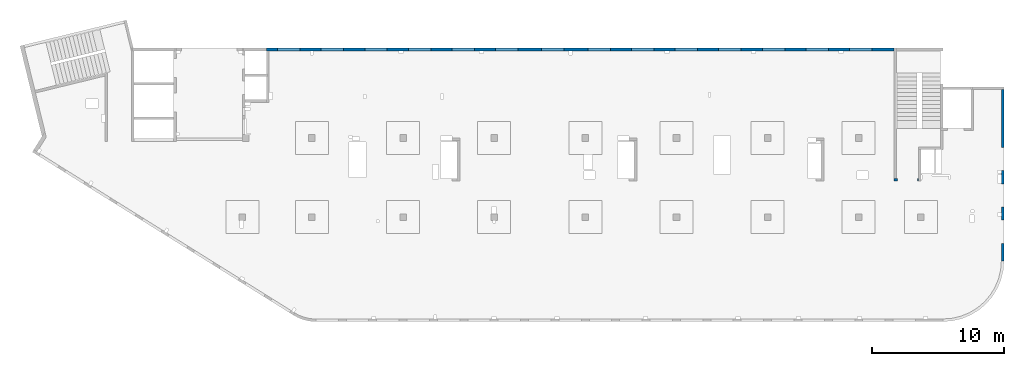
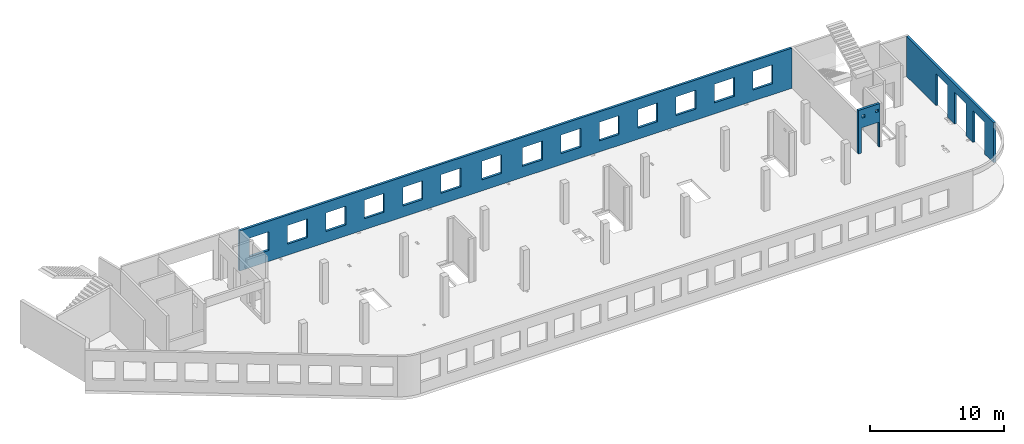
# One storey, part 6 of 6: 3 walls, 20 openings.
"""IFC4 building model written with IfcOpenShell, lengths in millimetres."""

from ifc_helpers import new_model, entity, si_unit, converted_unit, derived_unit, direction, frame, origin, place, context, subcontext, project, spatial, indexed_curve, outline, extrude, polygons, material, type_object, element, save


model = new_model("IFC4")

# Units and contexts
model_context = context("Model", 3, precision=0.01, world=origin(), true_north=direction((6.12303176911189e-17, 1.0)))
plan_context = context("Plan", 3, precision=0.01, world=origin(), true_north=direction((6.12303176911189e-17, 1.0)))
body_context = subcontext(model_context, "Body", "Model", "MODEL_VIEW")
ifc_project = project(units=[si_unit("LENGTHUNIT", "METRE", prefix="MILLI"), si_unit("AREAUNIT", "SQUARE_METRE"), si_unit("VOLUMEUNIT", "CUBIC_METRE"), converted_unit("PLANEANGLEUNIT", "DEGREE", entity("IfcRatioMeasure", 0.0174532925199433), si_unit("PLANEANGLEUNIT", "RADIAN"), dimensions=[0, 0, 0, 0, 0, 0, 0]), si_unit("MASSUNIT", "GRAM", prefix="KILO"), derived_unit("MASSDENSITYUNIT", [(si_unit("MASSUNIT", "GRAM", prefix="KILO"), 1), (si_unit("LENGTHUNIT", "METRE"), -3)]), derived_unit("MOMENTOFINERTIAUNIT", [(si_unit("LENGTHUNIT", "METRE"), 4)]), si_unit("TIMEUNIT", "SECOND"), si_unit("FREQUENCYUNIT", "HERTZ"), si_unit("THERMODYNAMICTEMPERATUREUNIT", "DEGREE_CELSIUS"), derived_unit("THERMALTRANSMITTANCEUNIT", [(si_unit("MASSUNIT", "GRAM", prefix="KILO"), 1), (si_unit("THERMODYNAMICTEMPERATUREUNIT", "KELVIN"), -1), (si_unit("TIMEUNIT", "SECOND"), -3)]), derived_unit("VOLUMETRICFLOWRATEUNIT", [(si_unit("LENGTHUNIT", "METRE"), 3), (si_unit("TIMEUNIT", "SECOND"), -1)]), derived_unit("MASSFLOWRATEUNIT", [(si_unit("MASSUNIT", "GRAM", prefix="KILO"), 1), (si_unit("TIMEUNIT", "SECOND"), -1)]), derived_unit("ROTATIONALFREQUENCYUNIT", [(si_unit("TIMEUNIT", "SECOND"), -1)]), si_unit("ELECTRICCURRENTUNIT", "AMPERE"), si_unit("ELECTRICVOLTAGEUNIT", "VOLT"), si_unit("POWERUNIT", "WATT"), si_unit("FORCEUNIT", "NEWTON", prefix="KILO"), si_unit("ILLUMINANCEUNIT", "LUX"), si_unit("LUMINOUSFLUXUNIT", "LUMEN"), si_unit("LUMINOUSINTENSITYUNIT", "CANDELA"), derived_unit("USERDEFINED", [(si_unit("MASSUNIT", "GRAM", prefix="KILO"), -1), (si_unit("LENGTHUNIT", "METRE"), -2), (si_unit("TIMEUNIT", "SECOND"), 3), (si_unit("LUMINOUSFLUXUNIT", "LUMEN"), 1)]), derived_unit("LINEARVELOCITYUNIT", [(si_unit("LENGTHUNIT", "METRE"), 1), (si_unit("TIMEUNIT", "SECOND"), -1)]), si_unit("PRESSUREUNIT", "PASCAL"), derived_unit("USERDEFINED", [(si_unit("LENGTHUNIT", "METRE"), -2), (si_unit("MASSUNIT", "GRAM", prefix="KILO"), 1), (si_unit("TIMEUNIT", "SECOND"), -2)]), derived_unit("LINEARFORCEUNIT", [(si_unit("MASSUNIT", "GRAM", prefix="KILO"), 1), (si_unit("LENGTHUNIT", "METRE"), 1), (si_unit("TIMEUNIT", "SECOND"), -2), (si_unit("LENGTHUNIT", "METRE"), -1)]), derived_unit("PLANARFORCEUNIT", [(si_unit("MASSUNIT", "GRAM", prefix="KILO"), 1), (si_unit("LENGTHUNIT", "METRE"), 1), (si_unit("TIMEUNIT", "SECOND"), -2), (si_unit("LENGTHUNIT", "METRE"), -2)])], contexts=[model_context, plan_context])

# Site, building, storey
site_placement = place(None, origin())
site = spatial("IfcSite", under=ifc_project, at=site_placement, CompositionType="ELEMENT")
building_placement = place(site_placement, origin())
building = spatial("IfcBuilding", under=site, at=building_placement, CompositionType="ELEMENT")
storey_placement = place(building_placement, frame((0.0, 0.0, 12000.0)))
storey = spatial("IfcBuildingStorey", under=building, at=storey_placement, Name="04", CompositionType="ELEMENT", Elevation=12000.0)

# Wall, openings
ifc_material = material()
wall_type = type_object("IfcWallType", Name=":ADSK_ 25_200", PredefinedType="STANDARD")
wall_1_placement = place(storey_placement, frame((73470.0, 17370.0, -150.0), z_axis=(0.0, 0.0, 1.0), x_axis=(0.0, -1.0, 0.0)))
wall_1 = element("IfcWall", 1, at=wall_1_placement, inside=storey, type_object=wall_type, material=ifc_material, Name=":ADSK_ 25_200", ObjectType=":ADSK_ 25_200", PredefinedType="NOTDEFINED", context=body_context, shape_type="Tessellation", body=[
    polygons([(12970.0, -99.9999999999918, 0.0), (12970.0, -99.9999999999918, 3200.0), (12970.0, -99.9999999999918, 3650.0), (9560.00000000002, -99.9999999999877, 3650.0), (9360.00000000002, -99.999999999988, 3650.0), (7085.00000000004, -99.999999999991, 3650.0), (6485.00000000003, -99.9999999999918, 3650.0), (6320.00000000002, -99.999999999992, 3650.0), (6120.00000000002, -99.9999999999923, 3650.0), (0.0, -99.9999999999831, 3650.0), (0.0, -99.9999999999831, 0.0), (4394.99999999951, -99.9999999999946, 0.0), (4394.99999999951, -100.000000000003, 2900.0), (6144.99999999951, -100.000000000001, 2900.0), (6144.99999999951, -99.9999999999923, 0.0), (6320.00000000002, -99.999999999992, 0.0), (6485.00000000003, -99.9999999999918, 0.0), (7085.00000000004, -99.999999999991, 0.0), (7144.99999999951, -99.9999999999909, 0.0), (7144.99999999951, -99.9999999999996, 2900.0), (8894.99999999951, -99.9999999999972, 2900.0), (8894.99999999951, -99.9999999999886, 0.0), (9360.00000000002, -99.999999999988, 0.0), (9560.00000000003, -99.9999999999877, 0.0), (9894.99999999951, -99.9999999999959, 0.0), (9894.99999999951, -99.9999999999959, 2900.0), (11644.9999999995, -99.9999999999936, 2900.0), (11644.9999999995, -99.9999999999936, 0.0), (12970.0, 100.000000000006, 3650.0), (12970.0, 100.000000000006, 3200.0), (12970.0, 100.000000000006, 0.0), (11644.9999999995, 100.000000000004, 0.0), (11644.9999999995, 100.000000000316, 2900.0), (9894.99999999951, 100.000000000314, 2900.0), (9894.99999999951, 100.000000000002, 0.0), (8894.99999999951, 100.000000000001, 0.0), (8894.99999999951, 100.00000000033, 2900.0), (7144.99999999951, 100.000000000327, 2900.0), (7144.99999999951, 99.9999999999983, 0.0), (6144.99999999951, 99.9999999999969, 0.0), (6144.99999999951, 100.000000000326, 2900.0), (4394.99999999951, 100.000000000324, 2900.0), (4394.99999999951, 99.9999999999946, 0.0), (0.0, 100.000000000006, 0.0), (0.0, 100.000000000006, 3650.0)], [[[1, 2, 3, 4, 5, 6, 7, 8, 9, 10, 11, 12, 13, 14, 15, 16, 17, 18, 19, 20, 21, 22, 23, 24, 25, 26, 27, 28]], [[29, 30, 31, 32, 33, 34, 35, 36, 37, 38, 39, 40, 41, 42, 43, 44, 45]], [[11, 44, 43, 12]], [[3, 2, 1, 31, 30, 29]], [[10, 9, 8, 7, 6, 5, 4, 3, 29, 45]], [[11, 10, 45, 44]], [[26, 34, 33, 27]], [[34, 26, 25, 35]], [[27, 33, 32, 28]], [[20, 38, 37, 21]], [[38, 20, 19, 39]], [[21, 37, 36, 22]], [[13, 42, 41, 14]], [[42, 13, 12, 43]], [[14, 41, 40, 15]], [[39, 19, 18, 17, 16, 15, 40]], [[35, 25, 24, 23, 22, 36]], [[31, 1, 28, 32]]], closed=True),
])
placement_1 = place(wall_1_placement, frame((17370.0, -73470.0, 150.0), z_axis=(0.0, 0.0, 1.0), x_axis=(0.0, 1.0, 0.0)))
element("IfcOpeningElement", 2, at=placement_1, cuts=wall_1, Name=":ADSK_ 25_200", PredefinedType="OPENING", context=body_context, shape_type="SweptSolid", body=[
    extrude(outline(indexed_curve([(-1449.99999999999, -874.999999999999), (1449.99999999999, -874.999999999999), (1449.99999999999, 875.0), (-1449.99999999999, 875.0), (-1449.99999999999, -874.999999999999)], self_intersect=False)), frame((73370.0, 6600.0, 1300.0), z_axis=(1.0, 0.0, 0.0), x_axis=(0.0, 0.0, -1.0)), (0.0, 0.0, 1.0), 200.000000000968),
])
element("IfcOpeningElement", 3, at=placement_1, cuts=wall_1, Name=":ADSK_ 25_200", PredefinedType="OPENING", context=body_context, shape_type="SweptSolid", body=[
    extrude(outline(indexed_curve([(-1449.99999999999, -875.0), (1449.99999999999, -875.0), (1449.99999999999, 874.999999999999), (-1449.99999999999, 874.999999999999), (-1449.99999999999, -875.0)], self_intersect=False)), frame((73370.0, 9350.0, 1300.0), z_axis=(1.0, 0.0, 0.0), x_axis=(0.0, 0.0, -1.0)), (0.0, 0.0, 1.0), 200.000000000968),
])
element("IfcOpeningElement", 4, at=placement_1, cuts=wall_1, Name=":ADSK_ 25_200", PredefinedType="OPENING", context=body_context, shape_type="SweptSolid", body=[
    extrude(outline(indexed_curve([(-1449.99999999999, -875.0), (1449.99999999999, -875.0), (1449.99999999999, 875.0), (-1449.99999999999, 875.0), (-1449.99999999999, -875.0)], self_intersect=False)), frame((73370.0, 12100.0, 1300.0), z_axis=(1.0, 0.0, 0.0), x_axis=(0.0, 0.0, -1.0)), (0.0, 0.0, 1.0), 200.000000000968),
])

wall_2_placement = place(storey_placement, frame((67080.0, 10525.0, -150.0), z_axis=(0.0, 0.0, 1.0), x_axis=(-1.0, 0.0, 0.0)))
wall_2 = element("IfcWall", 5, at=wall_2_placement, inside=storey, type_object=wall_type, material=ifc_material, Name=":ADSK_ 25_200", ObjectType=":ADSK_ 25_200", PredefinedType="NOTDEFINED", context=body_context, shape_type="Tessellation", body=[
    polygons([(1849.99999999999, -100.000000000001, 3950.0), (-9.772240076716e-13, -100.000000000001, 3950.0), (-9.772240076716e-13, -100.000000000001, 0.0), (74.9999999999906, -100.000000000001, 0.0), (74.9999999999906, -100.000000000001, 2279.99999999805), (1575.0, -100.000000000001, 2279.99999999804), (1575.0, -100.000000000003, 0.0), (1650.0, -100.000000000003, 0.0), (1849.99999999999, -100.000000000001, 0.0), (1849.99999999999, -100.000000000001, 3650.0), (125.000000000014, -100.000000000322, 3490.0), (375.000000000009, -100.000000000324, 3490.0), (375.000000000009, -100.000000000324, 3240.00000000001), (125.000000000014, -100.000000000322, 3240.00000000001), (1275.0, -100.000000000322, 3400.0), (1524.99999999999, -100.000000000322, 3400.0), (1524.99999999999, -100.000000000322, 3150.00000000001), (1275.0, -100.000000000322, 3150.00000000001), (-1.61109744921212e-12, 99.9999999999989, 3950.0), (1849.99999999999, 99.9999999999989, 3950.0), (1849.99999999999, 99.9999999999989, 0.0), (1575.0, 99.9999999999968, 0.0), (1575.0, 99.9999999999968, 2279.99999999804), (74.99999999999, 99.9999999999989, 2279.99999999805), (74.99999999999, 99.9999999999989, 0.0), (-1.61109744921212e-12, 99.9999999999989, 0.0), (375.000000000008, 99.9999999999968, 3490.0), (125.000000000013, 99.9999999999968, 3490.0), (125.000000000013, 99.9999999999968, 3240.00000000001), (375.000000000008, 99.9999999999968, 3240.00000000001), (1524.99999999999, 99.9999999999968, 3400.0), (1275.0, 99.9999999999989, 3400.0), (1275.0, 99.9999999999989, 3150.00000000001), (1524.99999999999, 99.9999999999968, 3150.00000000001)], [[[1, 2, 3, 4, 5, 6, 7, 8, 9, 10], [11, 12, 13, 14], [15, 16, 17, 18]], [[19, 20, 21, 22, 23, 24, 25, 26], [27, 28, 29, 30], [31, 32, 33, 34]], [[3, 26, 25, 4]], [[2, 1, 20, 19]], [[3, 2, 19, 26]], [[1, 10, 9, 21, 20]], [[12, 11, 28, 27]], [[12, 27, 30, 13]], [[13, 30, 29, 14]], [[28, 11, 14, 29]], [[16, 15, 32, 31]], [[16, 31, 34, 17]], [[17, 34, 33, 18]], [[32, 15, 18, 33]], [[5, 24, 23, 6]], [[6, 23, 22, 7]], [[24, 5, 4, 25]], [[21, 9, 8, 7, 22]]], closed=True),
])
placement_2 = place(wall_2_placement, frame((67080.0, 10525.0, 150.0), z_axis=(0.0, 0.0, 1.0), x_axis=(-1.0, 0.0, 0.0)))
element("IfcOpeningElement", 6, at=placement_2, cuts=wall_2, Name=":ADSK_ 25_200", PredefinedType="OPENING", context=body_context, shape_type="SweptSolid", body=[
    extrude(outline(indexed_curve([(-750.000000000003, -1139.99999999902), (749.999999999994, -1139.99999999902), (749.999999999994, 1139.99999999902), (-750.000000000003, 1139.99999999902), (-750.000000000003, -1139.99999999902)], self_intersect=False)), frame((66255.0, 10725.0, 990.0), z_axis=(0.0, -1.0, 0.0), x_axis=(-1.0, 0.0, 0.0)), (0.0, 0.0, 1.0), 400.000000001943),
])
element("IfcOpeningElement", 7, at=placement_2, cuts=wall_2, Name=":ADSK_ 25_200", PredefinedType="OPENING", context=body_context, shape_type="SweptSolid", body=[
    extrude(outline(indexed_curve([(-125.000000000006, -124.999999999993), (124.999999999998, -124.999999999993), (124.999999999998, 124.999999999993), (-125.000000000006, 124.999999999993), (-125.000000000006, -124.999999999993)], self_intersect=False)), frame((65680.0, 10625.0, 3125.0), z_axis=(0.0, -1.0, 0.0), x_axis=(-1.0, 0.0, 0.0)), (0.0, 0.0, 1.0), 200.000000000962),
])
element("IfcOpeningElement", 8, at=placement_2, cuts=wall_2, Name=":ADSK_ 25_200", PredefinedType="OPENING", context=body_context, shape_type="SweptSolid", body=[
    extrude(outline(indexed_curve([(-125.000000000006, -124.999999999993), (124.999999999998, -124.999999999993), (124.999999999998, 124.999999999993), (-125.000000000006, 124.999999999993), (-125.000000000006, -124.999999999993)], self_intersect=False)), frame((66830.0, 10625.0, 3215.0), z_axis=(0.0, -1.0, 0.0), x_axis=(-1.0, 0.0, 0.0)), (0.0, 0.0, 1.0), 200.000000000962),
])

wall_3_placement = place(storey_placement, frame((65230.0, 20400.0, -150.0), z_axis=(0.0, 0.0, 1.0), x_axis=(-1.0, 0.0, 0.0)))
wall_3 = element("IfcWall", 9, at=wall_3_placement, inside=storey, type_object=wall_type, material=ifc_material, Name=":ADSK_ 25_200", ObjectType=":ADSK_ 25_200", PredefinedType="NOTDEFINED", context=body_context, shape_type="Tessellation", body=[
    polygons([(8.66293703438714e-12, -99.9999999999989, 0.0), (47505.0, -99.9999999999989, 0.0), (47505.0, -99.9999999999989, 3650.0), (47405.0, -99.9999999999989, 3650.0), (8.66293703438714e-12, -99.9999999999989, 3650.0), (28460.0, -100.000000000319, 2700.0), (30160.0, -100.000000000319, 2700.0), (30160.0, -100.000000000319, 1000.00000000001), (28460.0, -100.000000000319, 1000.00000000001), (1660.00000000009, -100.000000000319, 2700.0), (3360.00000000009, -100.000000000319, 2700.0), (3360.00000000009, -100.000000000319, 1000.00000000001), (1660.00000000009, -100.000000000319, 1000.00000000001), (4960.00000000009, -100.000000000319, 2700.0), (6660.00000000009, -100.000000000319, 2700.0), (6660.00000000009, -100.000000000319, 1000.00000000001), (4960.00000000009, -100.000000000319, 1000.00000000001), (8260.00000000008, -100.000000000319, 2700.0), (9960.00000000008, -100.000000000319, 2700.0), (9960.00000000008, -100.000000000319, 1000.00000000001), (8260.00000000008, -100.000000000319, 1000.00000000001), (11560.0000000001, -100.000000000319, 2700.0), (13260.0000000001, -100.000000000319, 2700.0), (13260.0000000001, -100.000000000319, 1000.00000000001), (11560.0000000001, -100.000000000319, 1000.00000000001), (14860.0000000001, -100.000000000319, 2700.0), (16560.0000000001, -100.000000000319, 2700.0), (16560.0000000001, -100.000000000319, 1000.00000000001), (14860.0000000001, -100.000000000319, 1000.00000000001), (18160.0000000001, -100.000000000319, 2700.0), (19860.0000000001, -100.000000000319, 2700.0), (19860.0000000001, -100.000000000319, 1000.00000000001), (18160.0000000001, -100.000000000319, 1000.00000000001), (21460.0000000001, -100.000000000319, 2700.0), (23160.0000000001, -100.000000000319, 2700.0), (23160.0000000001, -100.000000000319, 1000.00000000001), (21460.0000000001, -100.000000000319, 1000.00000000001), (24960.0000000001, -100.000000000319, 2700.0), (26660.0000000001, -100.000000000319, 2700.0), (26660.0000000001, -100.000000000319, 1000.00000000001), (24960.0000000001, -100.000000000319, 1000.00000000001), (31760.0000000001, -100.000000000319, 2700.0), (33460.0000000001, -100.000000000319, 2700.0), (33460.0000000001, -100.000000000319, 1000.00000000001), (31760.0000000001, -100.000000000319, 1000.00000000001), (35060.0000000001, -100.000000000319, 2700.0), (36760.0000000001, -100.000000000319, 2700.0), (36760.0000000001, -100.000000000319, 1000.00000000001), (35060.0000000001, -100.000000000319, 1000.00000000001), (38360.0000000001, -100.000000000319, 2700.0), (40060.0000000001, -100.000000000319, 2700.0), (40060.0000000001, -100.000000000319, 1000.00000000001), (38360.0000000001, -100.000000000319, 1000.00000000001), (41660.0, -100.000000000319, 2700.0), (43360.0, -100.000000000319, 2700.0), (43360.0, -100.000000000319, 1000.00000000001), (41660.0, -100.000000000319, 1000.00000000001), (44960.0, -100.000000000319, 2700.0), (46660.0, -100.000000000319, 2700.0), (46660.0, -100.000000000319, 1000.00000000001), (44960.0, -100.000000000319, 1000.00000000001), (30160.0, 99.9999999999989, 2699.99999999999), (28460.0, 99.9999999999989, 2699.99999999999), (28460.0, 99.9999999999989, 1000.00000000001), (30160.0, 99.9999999999989, 1000.00000000001), (3360.00000000009, 99.9999999999989, 2699.99999999999), (1660.00000000009, 99.9999999999989, 2699.99999999999), (1660.00000000009, 99.9999999999989, 1000.00000000001), (3360.00000000009, 99.9999999999989, 1000.00000000001), (6660.00000000009, 99.9999999999989, 2699.99999999999), (4960.00000000009, 99.9999999999989, 2699.99999999999), (4960.00000000009, 99.9999999999989, 1000.00000000001), (6660.00000000009, 99.9999999999989, 1000.00000000001), (9960.00000000008, 99.9999999999989, 2699.99999999999), (8260.00000000008, 99.9999999999989, 2699.99999999999), (8260.00000000008, 99.9999999999989, 1000.00000000001), (9960.00000000008, 99.9999999999989, 1000.00000000001), (13260.0000000001, 99.9999999999989, 2699.99999999999), (11560.0000000001, 99.9999999999989, 2699.99999999999), (11560.0000000001, 99.9999999999989, 1000.00000000001), (13260.0000000001, 99.9999999999989, 1000.00000000001), (16560.0000000001, 99.9999999999989, 2699.99999999999), (14860.0000000001, 99.9999999999989, 2699.99999999999), (14860.0000000001, 99.9999999999989, 1000.00000000001), (16560.0000000001, 99.9999999999989, 1000.00000000001), (19860.0000000001, 99.9999999999989, 2699.99999999999), (18160.0000000001, 99.9999999999989, 2699.99999999999), (18160.0000000001, 99.9999999999989, 1000.00000000001), (19860.0000000001, 99.9999999999989, 1000.00000000001), (23160.0000000001, 99.9999999999989, 2699.99999999999), (21460.0000000001, 99.9999999999989, 2699.99999999999), (21460.0000000001, 99.9999999999989, 1000.00000000001), (23160.0000000001, 99.9999999999989, 1000.00000000001), (26660.0000000001, 99.9999999999989, 2699.99999999999), (24960.0000000001, 99.9999999999989, 2699.99999999999), (24960.0000000001, 99.9999999999989, 1000.00000000001), (26660.0000000001, 99.9999999999989, 1000.00000000001), (33460.0000000001, 99.9999999999989, 2699.99999999999), (31760.0000000001, 99.9999999999989, 2699.99999999999), (31760.0000000001, 99.9999999999989, 1000.00000000001), (33460.0000000001, 99.9999999999989, 1000.00000000001), (36760.0000000001, 99.9999999999989, 2699.99999999999), (35060.0000000001, 99.9999999999989, 2699.99999999999), (35060.0000000001, 99.9999999999989, 1000.00000000001), (36760.0000000001, 99.9999999999989, 1000.00000000001), (40060.0000000001, 99.9999999999989, 2699.99999999999), (38360.0000000001, 99.9999999999989, 2699.99999999999), (38360.0000000001, 99.9999999999989, 1000.00000000001), (40060.0000000001, 99.9999999999989, 1000.00000000001), (43360.0, 99.9999999999989, 2699.99999999999), (41660.0, 99.9999999999989, 2699.99999999999), (41660.0, 99.9999999999989, 1000.00000000001), (43360.0, 99.9999999999989, 1000.00000000001), (46660.0, 99.9999999999989, 2699.99999999999), (44960.0, 99.9999999999989, 2699.99999999999), (44960.0, 99.9999999999989, 1000.00000000001), (46660.0, 99.9999999999989, 1000.00000000001), (8.66293703438714e-12, 99.9999999999989, 0.0), (8.66293703438714e-12, 99.9999999999989, 3650.0), (47305.0, 99.9999999999989, 3650.0), (47405.0, 99.9999999999989, 3650.0), (47505.0, 99.9999999999989, 3650.0), (47505.0, 99.9999999999989, 0.0), (47305.0, 99.9999999999989, 0.0)], [[[1, 2, 3, 4, 5], [6, 7, 8, 9], [10, 11, 12, 13], [14, 15, 16, 17], [18, 19, 20, 21], [22, 23, 24, 25], [26, 27, 28, 29], [30, 31, 32, 33], [34, 35, 36, 37], [38, 39, 40, 41], [42, 43, 44, 45], [46, 47, 48, 49], [50, 51, 52, 53], [54, 55, 56, 57], [58, 59, 60, 61]], [[118, 119, 120, 121, 122, 123, 124], [62, 63, 64, 65], [66, 67, 68, 69], [70, 71, 72, 73], [74, 75, 76, 77], [78, 79, 80, 81], [82, 83, 84, 85], [86, 87, 88, 89], [90, 91, 92, 93], [94, 95, 96, 97], [98, 99, 100, 101], [102, 103, 104, 105], [106, 107, 108, 109], [110, 111, 112, 113], [114, 115, 116, 117]], [[2, 1, 118, 124, 123]], [[5, 4, 3, 122, 121, 120, 119]], [[7, 6, 63, 62]], [[7, 62, 65, 8]], [[8, 65, 64, 9]], [[63, 6, 9, 64]], [[11, 10, 67, 66]], [[11, 66, 69, 12]], [[12, 69, 68, 13]], [[67, 10, 13, 68]], [[15, 14, 71, 70]], [[15, 70, 73, 16]], [[16, 73, 72, 17]], [[71, 14, 17, 72]], [[19, 18, 75, 74]], [[19, 74, 77, 20]], [[20, 77, 76, 21]], [[75, 18, 21, 76]], [[23, 22, 79, 78]], [[23, 78, 81, 24]], [[24, 81, 80, 25]], [[79, 22, 25, 80]], [[27, 26, 83, 82]], [[27, 82, 85, 28]], [[28, 85, 84, 29]], [[83, 26, 29, 84]], [[31, 30, 87, 86]], [[31, 86, 89, 32]], [[32, 89, 88, 33]], [[87, 30, 33, 88]], [[35, 34, 91, 90]], [[35, 90, 93, 36]], [[36, 93, 92, 37]], [[91, 34, 37, 92]], [[39, 38, 95, 94]], [[39, 94, 97, 40]], [[40, 97, 96, 41]], [[95, 38, 41, 96]], [[43, 42, 99, 98]], [[43, 98, 101, 44]], [[44, 101, 100, 45]], [[99, 42, 45, 100]], [[47, 46, 103, 102]], [[47, 102, 105, 48]], [[48, 105, 104, 49]], [[103, 46, 49, 104]], [[51, 50, 107, 106]], [[51, 106, 109, 52]], [[52, 109, 108, 53]], [[107, 50, 53, 108]], [[55, 54, 111, 110]], [[55, 110, 113, 56]], [[56, 113, 112, 57]], [[111, 54, 57, 112]], [[59, 58, 115, 114]], [[59, 114, 117, 60]], [[60, 117, 116, 61]], [[115, 58, 61, 116]], [[1, 5, 119, 118]], [[3, 2, 123, 122]]], closed=True),
])
placement_3 = place(wall_3_placement, frame((65230.0, 20400.0, 150.0), z_axis=(0.0, 0.0, 1.0), x_axis=(-1.0, 0.0, 0.0)))
element("IfcOpeningElement", 10, at=placement_3, cuts=wall_3, Name=":ADSK_ 25_200", PredefinedType="OPENING", context=body_context, shape_type="SweptSolid", body=[
    extrude(outline(indexed_curve([(-850.000000000002, -849.999999999995), (850.0, -849.999999999995), (850.0, 849.999999999993), (-850.000000000002, 849.999999999993), (-850.000000000002, -849.999999999995)], self_intersect=False)), frame((19420.0, 20500.0, 1700.0), z_axis=(0.0, -1.0, 0.0), x_axis=(-1.0, 0.0, 0.0)), (0.0, 0.0, 1.0), 200.000000000959),
])
element("IfcOpeningElement", 11, at=placement_3, cuts=wall_3, Name=":ADSK_ 25_200", PredefinedType="OPENING", context=body_context, shape_type="SweptSolid", body=[
    extrude(outline(indexed_curve([(-850.000000000002, -849.999999999995), (849.999999999997, -849.999999999995), (849.999999999997, 849.999999999993), (-850.000000000002, 849.999999999993), (-850.000000000002, -849.999999999995)], self_intersect=False)), frame((22720.0, 20500.0, 1700.0), z_axis=(0.0, -1.0, 0.0), x_axis=(-1.0, 0.0, 0.0)), (0.0, 0.0, 1.0), 200.000000000959),
])
element("IfcOpeningElement", 12, at=placement_3, cuts=wall_3, Name=":ADSK_ 25_200", PredefinedType="OPENING", context=body_context, shape_type="SweptSolid", body=[
    extrude(outline(indexed_curve([(-850.000000000002, -849.999999999995), (849.999999999997, -849.999999999995), (849.999999999997, 849.999999999993), (-850.000000000002, 849.999999999993), (-850.000000000002, -849.999999999995)], self_intersect=False)), frame((26020.0, 20500.0, 1700.0), z_axis=(0.0, -1.0, 0.0), x_axis=(-1.0, 0.0, 0.0)), (0.0, 0.0, 1.0), 200.000000000959),
])
element("IfcOpeningElement", 13, at=placement_3, cuts=wall_3, Name=":ADSK_ 25_200", PredefinedType="OPENING", context=body_context, shape_type="SweptSolid", body=[
    extrude(outline(indexed_curve([(-850.000000000002, -849.999999999995), (849.999999999997, -849.999999999995), (849.999999999997, 849.999999999993), (-850.000000000002, 849.999999999993), (-850.000000000002, -849.999999999995)], self_intersect=False)), frame((29320.0, 20500.0, 1700.0), z_axis=(0.0, -1.0, 0.0), x_axis=(-1.0, 0.0, 0.0)), (0.0, 0.0, 1.0), 200.000000000959),
])
element("IfcOpeningElement", 14, at=placement_3, cuts=wall_3, Name=":ADSK_ 25_200", PredefinedType="OPENING", context=body_context, shape_type="SweptSolid", body=[
    extrude(outline(indexed_curve([(-849.999999999997, -849.999999999995), (850.000000000002, -849.999999999995), (850.000000000002, 849.999999999993), (-849.999999999997, 849.999999999993), (-849.999999999997, -849.999999999995)], self_intersect=False)), frame((32620.0, 20500.0, 1700.0), z_axis=(0.0, -1.0, 0.0), x_axis=(-1.0, 0.0, 0.0)), (0.0, 0.0, 1.0), 200.000000000959),
])
element("IfcOpeningElement", 15, at=placement_3, cuts=wall_3, Name=":ADSK_ 25_200", PredefinedType="OPENING", context=body_context, shape_type="SweptSolid", body=[
    extrude(outline(indexed_curve([(-849.999999999997, -849.999999999995), (850.000000000006, -849.999999999995), (850.000000000006, 849.999999999993), (-849.999999999997, 849.999999999993), (-849.999999999997, -849.999999999995)], self_intersect=False)), frame((39420.0, 20500.0, 1700.0), z_axis=(0.0, -1.0, 0.0), x_axis=(-1.0, 0.0, 0.0)), (0.0, 0.0, 1.0), 200.000000000959),
])
element("IfcOpeningElement", 16, at=placement_3, cuts=wall_3, Name=":ADSK_ 25_200", PredefinedType="OPENING", context=body_context, shape_type="SweptSolid", body=[
    extrude(outline(indexed_curve([(-850.000000000006, -849.999999999995), (849.999999999997, -849.999999999995), (849.999999999997, 849.999999999993), (-850.000000000006, 849.999999999993), (-850.000000000006, -849.999999999995)], self_intersect=False)), frame((42920.0, 20500.0, 1700.0), z_axis=(0.0, -1.0, 0.0), x_axis=(-1.0, 0.0, 0.0)), (0.0, 0.0, 1.0), 200.000000000959),
])
element("IfcOpeningElement", 17, at=placement_3, cuts=wall_3, Name=":ADSK_ 25_200", PredefinedType="OPENING", context=body_context, shape_type="SweptSolid", body=[
    extrude(outline(indexed_curve([(-849.999999999997, -849.999999999995), (850.000000000006, -849.999999999995), (850.000000000006, 849.999999999993), (-849.999999999997, 849.999999999993), (-849.999999999997, -849.999999999995)], self_intersect=False)), frame((46220.0, 20500.0, 1700.0), z_axis=(0.0, -1.0, 0.0), x_axis=(-1.0, 0.0, 0.0)), (0.0, 0.0, 1.0), 200.000000000959),
])
element("IfcOpeningElement", 18, at=placement_3, cuts=wall_3, Name=":ADSK_ 25_200", PredefinedType="OPENING", context=body_context, shape_type="SweptSolid", body=[
    extrude(outline(indexed_curve([(-849.999999999997, -849.999999999995), (850.000000000006, -849.999999999995), (850.000000000006, 849.999999999993), (-849.999999999997, 849.999999999993), (-849.999999999997, -849.999999999995)], self_intersect=False)), frame((49520.0, 20500.0, 1700.0), z_axis=(0.0, -1.0, 0.0), x_axis=(-1.0, 0.0, 0.0)), (0.0, 0.0, 1.0), 200.000000000959),
])
element("IfcOpeningElement", 19, at=placement_3, cuts=wall_3, Name=":ADSK_ 25_200", PredefinedType="OPENING", context=body_context, shape_type="SweptSolid", body=[
    extrude(outline(indexed_curve([(-849.999999999997, -849.999999999995), (850.000000000006, -849.999999999995), (850.000000000006, 849.999999999993), (-849.999999999997, 849.999999999993), (-849.999999999997, -849.999999999995)], self_intersect=False)), frame((52820.0, 20500.0, 1700.0), z_axis=(0.0, -1.0, 0.0), x_axis=(-1.0, 0.0, 0.0)), (0.0, 0.0, 1.0), 200.000000000959),
])
element("IfcOpeningElement", 20, at=placement_3, cuts=wall_3, Name=":ADSK_ 25_200", PredefinedType="OPENING", context=body_context, shape_type="SweptSolid", body=[
    extrude(outline(indexed_curve([(-849.999999999997, -849.999999999995), (850.000000000006, -849.999999999995), (850.000000000006, 849.999999999993), (-849.999999999997, 849.999999999993), (-849.999999999997, -849.999999999995)], self_intersect=False)), frame((56120.0, 20500.0, 1700.0), z_axis=(0.0, -1.0, 0.0), x_axis=(-1.0, 0.0, 0.0)), (0.0, 0.0, 1.0), 200.000000000959),
])
element("IfcOpeningElement", 21, at=placement_3, cuts=wall_3, Name=":ADSK_ 25_200", PredefinedType="OPENING", context=body_context, shape_type="SweptSolid", body=[
    extrude(outline(indexed_curve([(-849.999999999997, -849.999999999995), (850.000000000006, -849.999999999995), (850.000000000006, 849.999999999993), (-849.999999999997, 849.999999999993), (-849.999999999997, -849.999999999995)], self_intersect=False)), frame((59420.0, 20500.0, 1700.0), z_axis=(0.0, -1.0, 0.0), x_axis=(-1.0, 0.0, 0.0)), (0.0, 0.0, 1.0), 200.000000000959),
])
element("IfcOpeningElement", 22, at=placement_3, cuts=wall_3, Name=":ADSK_ 25_200", PredefinedType="OPENING", context=body_context, shape_type="SweptSolid", body=[
    extrude(outline(indexed_curve([(-849.999999999997, -849.999999999995), (850.000000000006, -849.999999999995), (850.000000000006, 849.999999999993), (-849.999999999997, 849.999999999993), (-849.999999999997, -849.999999999995)], self_intersect=False)), frame((62720.0, 20500.0, 1700.0), z_axis=(0.0, -1.0, 0.0), x_axis=(-1.0, 0.0, 0.0)), (0.0, 0.0, 1.0), 200.000000000959),
])
element("IfcOpeningElement", 23, at=placement_3, cuts=wall_3, Name=":ADSK_ 25_200", PredefinedType="OPENING", context=body_context, shape_type="SweptSolid", body=[
    extrude(outline(indexed_curve([(-849.999999999997, -849.999999999995), (850.000000000002, -849.999999999995), (850.000000000002, 849.999999999993), (-849.999999999997, 849.999999999993), (-849.999999999997, -849.999999999995)], self_intersect=False)), frame((35920.0, 20500.0, 1700.0), z_axis=(0.0, -1.0, 0.0), x_axis=(-1.0, 0.0, 0.0)), (0.0, 0.0, 1.0), 200.000000000959),
])

save(model, "model.ifc")
